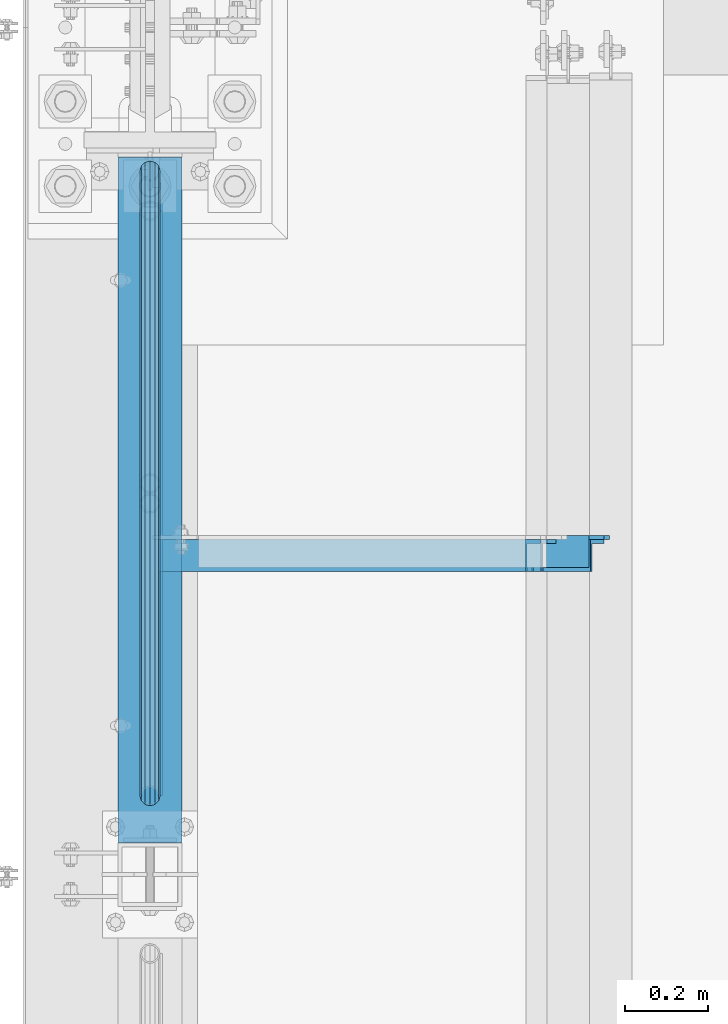
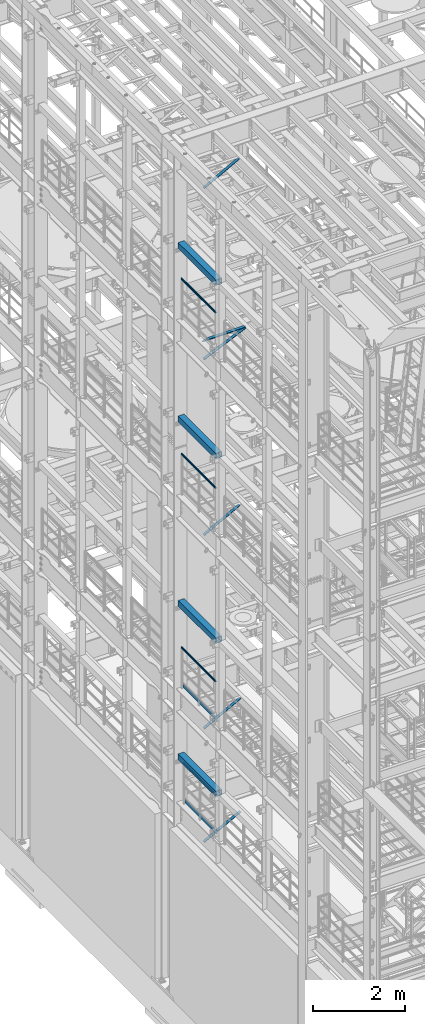
# One storey, part 1010 of 1876: 11 beams, 5 members, 14 elements without a shape of their own.
"""IFC2X3 building model written with IfcOpenShell, lengths in millimetres."""

from ifc_helpers import new_model, si_unit, frame, origin_with_axes, place, context, subcontext, project, spatial, faceted_brep, material, type_object, element, aggregate, save


model = new_model("IFC2X3")

# Units and contexts
model_context = context("Model", 3, precision=1e-05, world=origin_with_axes())
body_context = subcontext(model_context, "Body", "Model", "MODEL_VIEW")
ifc_project = project(units=[si_unit("LENGTHUNIT", "METRE", prefix="MILLI"), si_unit("AREAUNIT", "SQUARE_METRE"), si_unit("VOLUMEUNIT", "CUBIC_METRE"), si_unit("MASSUNIT", "GRAM", prefix="KILO"), si_unit("TIMEUNIT", "SECOND"), si_unit("PLANEANGLEUNIT", "RADIAN"), si_unit("SOLIDANGLEUNIT", "STERADIAN"), si_unit("THERMODYNAMICTEMPERATUREUNIT", "DEGREE_CELSIUS"), si_unit("LUMINOUSINTENSITYUNIT", "LUMEN")], contexts=[model_context])

# Site, building, storey
site_placement = place(None, origin_with_axes())
site = spatial("IfcSite", under=ifc_project, at=site_placement, CompositionType="ELEMENT")
building_placement = place(site_placement, origin_with_axes())
building = spatial("IfcBuilding", under=site, at=building_placement, Name="Undefined", CompositionType="ELEMENT")
storey_placement = place(building_placement, origin_with_axes())
storey = spatial("IfcBuildingStorey", under=building, at=storey_placement, Name="Undefined", CompositionType="ELEMENT", Elevation=0.0)

# Assembly, beam
assembly_1_placement = place(storey_placement, origin_with_axes())
assembly_1 = element("IfcElementAssembly", 1, at=assembly_1_placement, inside=storey, Name="RAIL", AssemblyPlace="NOTDEFINED", PredefinedType="RIGID_FRAME")
ifc_material_1 = material()
beam_type_1 = type_object("IfcBeamType", Name="PIPE1-1/2SCH40", PredefinedType="NOTDEFINED")
beam_1_placement = place(assembly_1_placement, frame((-1.81898940354586e-12, -342.900000000001, 19059.525), z_axis=(0.0, 0.0, -1.0), x_axis=(0.0, 1.0, 0.0)))
beam_1 = element("IfcBeam", 2, at=beam_1_placement, type_object=beam_type_1, material=ifc_material_1, Name="RAIL", ObjectType="PIPE1-1/2SCH40", context=body_context, shape_type="Brep", body=[
    faceted_brep([(24.1300000000001, -20.4469999999999, 0.0), (34.3535000000002, -17.7076214311803, 10.2235000000001), (1511.8715, -17.7076214311801, 10.2235000000001), (1522.095, -20.4470000000001, 0.0), (41.8376214311802, -10.2235000000001, 17.7076214311819), (1504.38737856882, -10.2235000000001, 17.7076214311819), (44.5770000000002, 0.0, 20.4470000000001), (1501.648, 0.0, 20.4470000000001), (41.8376214311802, 10.2235000000001, 17.7076214311819), (1504.38737856882, 10.2235000000001, 17.7076214311819), (34.3535000000002, 17.7076214311803, 10.2235000000001), (1511.8715, 17.7076214311801, 10.2235000000001), (24.1300000000001, 20.4469999999999, 0.0), (1522.095, 20.4470000000001, 0.0), (13.9065000000001, 17.7076214311803, -10.2235000000001), (1532.3185, 17.7076214311801, -10.2235000000001), (6.42237856882002, 10.2235000000001, -17.7076214311819), (1539.80262143118, 10.2235000000001, -17.7076214311819), (3.68299999999999, 0.0, -20.4470000000001), (1542.542, 0.0, -20.4470000000001), (6.42237856882002, -10.2235000000001, -17.7076214311819), (1539.80262143118, -10.2235000000001, -17.7076214311819), (13.9065000000001, -17.7076214311803, -10.2235000000001), (1532.3185, -17.7076214311801, -10.2235000000001), (24.1299999999854, -24.1299999999992, 0.0), (12.0650000000064, -20.8971929933177, -12.0649999999987), (1534.16, -20.8971929933186, -12.0649999999987), (1522.095, -24.1300000000001, 0.0), (3.23280700668147, -12.0650000000001, -20.8971929933177), (1542.99219299332, -12.0649999999996, -20.8971929933177), (-1.45519152283669e-11, 0.0, -24.130000000001), (1546.225, 0.0, -24.130000000001), (3.23280700668147, 12.0650000000001, -20.8971929933177), (1542.99219299332, 12.0649999999996, -20.8971929933177), (12.0650000000064, 20.8971929933177, -12.0649999999987), (1534.16, 20.8971929933186, -12.0649999999987), (24.1300000000047, 24.1299999999992, 0.0), (1522.095, 24.1300000000001, 0.0), (36.1949999999997, 20.8971929933184, 12.0649999999987), (1510.03, 20.8971929933186, 12.0649999999987), (45.0271929933187, 12.0650000000001, 20.8971929933177), (1501.19780700668, 12.0649999999996, 20.8971929933177), (48.2600000000002, 0.0, 24.130000000001), (1497.965, 0.0, 24.130000000001), (45.0271929933187, -12.0650000000001, 20.8971929933177), (1501.19780700668, -12.0649999999996, 20.8971929933177), (36.1949999999997, -20.8971929933184, 12.0649999999987), (1510.03, -20.8971929933186, 12.0649999999987)], [[[0, 1, 2, 3]], [[1, 4, 5, 2]], [[4, 6, 7, 5]], [[6, 8, 9, 7]], [[8, 10, 11, 9]], [[10, 12, 13, 11]], [[12, 14, 15, 13]], [[14, 16, 17, 15]], [[16, 18, 19, 17]], [[18, 20, 21, 19]], [[20, 22, 23, 21]], [[22, 0, 3, 23]], [[24, 25, 26, 27]], [[25, 28, 29, 26]], [[28, 30, 31, 29]], [[30, 32, 33, 31]], [[32, 34, 35, 33]], [[34, 36, 37, 35]], [[36, 38, 39, 37]], [[38, 40, 41, 39]], [[40, 42, 43, 41]], [[42, 44, 45, 43]], [[44, 46, 47, 45]], [[46, 24, 27, 47]], [[29, 31, 33, 35, 37, 39, 41, 43, 45, 47, 27, 26], [5, 7, 9, 11, 13, 15, 17, 19, 21, 23, 3, 2]], [[46, 44, 42, 40, 38, 36, 34, 32, 30, 28, 25, 24], [22, 20, 18, 16, 14, 12, 10, 8, 6, 4, 1, 0]]]),
])
aggregate(assembly_1, [beam_1])

assembly_2_placement = place(storey_placement, origin_with_axes())
assembly_2 = element("IfcElementAssembly", 3, at=assembly_2_placement, inside=storey, Name="RAIL", AssemblyPlace="NOTDEFINED", PredefinedType="RIGID_FRAME")
beam_2_placement = place(assembly_2_placement, frame((-1.81898940354586e-12, -342.900000000001, 14385.925), z_axis=(0.0, 0.0, -1.0), x_axis=(0.0, 1.0, 0.0)))
beam_2 = element("IfcBeam", 4, at=beam_2_placement, type_object=beam_type_1, material=ifc_material_1, Name="RAIL", ObjectType="PIPE1-1/2SCH40", context=body_context, shape_type="Brep", body=[
    faceted_brep([(24.1300000000001, -20.4469999999999, 0.0), (34.3535000000002, -17.7076214311803, 10.2235000000001), (1511.8715, -17.7076214311801, 10.2235000000001), (1522.095, -20.4470000000001, 0.0), (41.8376214311802, -10.2235000000001, 17.7076214311819), (1504.38737856882, -10.2235000000001, 17.7076214311819), (44.5770000000002, 0.0, 20.4470000000001), (1501.648, 0.0, 20.4470000000001), (41.8376214311802, 10.2235000000001, 17.7076214311819), (1504.38737856882, 10.2235000000001, 17.7076214311819), (34.3535000000002, 17.7076214311803, 10.2235000000001), (1511.8715, 17.7076214311801, 10.2235000000001), (24.1300000000001, 20.4469999999999, 0.0), (1522.095, 20.4470000000001, 0.0), (13.9065000000001, 17.7076214311803, -10.2235000000001), (1532.3185, 17.7076214311801, -10.2235000000001), (6.42237856882002, 10.2235000000001, -17.7076214311819), (1539.80262143118, 10.2235000000001, -17.7076214311819), (3.68299999999999, 0.0, -20.4470000000001), (1542.542, 0.0, -20.4470000000001), (6.42237856882002, -10.2235000000001, -17.7076214311819), (1539.80262143118, -10.2235000000001, -17.7076214311819), (13.9065000000001, -17.7076214311803, -10.2235000000001), (1532.3185, -17.7076214311801, -10.2235000000001), (24.1299999999854, -24.1299999999992, 0.0), (12.0650000000064, -20.8971929933177, -12.0649999999987), (1534.16, -20.8971929933186, -12.0649999999987), (1522.095, -24.1300000000001, 0.0), (3.23280700668147, -12.0650000000001, -20.8971929933177), (1542.99219299332, -12.0649999999996, -20.8971929933177), (-1.45519152283669e-11, 0.0, -24.130000000001), (1546.225, 0.0, -24.130000000001), (3.23280700668147, 12.0650000000001, -20.8971929933177), (1542.99219299332, 12.0649999999996, -20.8971929933177), (12.0650000000064, 20.8971929933177, -12.0649999999987), (1534.16, 20.8971929933186, -12.0649999999987), (24.1300000000047, 24.1299999999992, 0.0), (1522.095, 24.1300000000001, 0.0), (36.1949999999997, 20.8971929933184, 12.0649999999987), (1510.03, 20.8971929933186, 12.0649999999987), (45.0271929933187, 12.0650000000001, 20.8971929933177), (1501.19780700668, 12.0649999999996, 20.8971929933177), (48.2600000000002, 0.0, 24.130000000001), (1497.965, 0.0, 24.130000000001), (45.0271929933187, -12.0650000000001, 20.8971929933177), (1501.19780700668, -12.0649999999996, 20.8971929933177), (36.1949999999997, -20.8971929933184, 12.0649999999987), (1510.03, -20.8971929933186, 12.0649999999987)], [[[0, 1, 2, 3]], [[1, 4, 5, 2]], [[4, 6, 7, 5]], [[6, 8, 9, 7]], [[8, 10, 11, 9]], [[10, 12, 13, 11]], [[12, 14, 15, 13]], [[14, 16, 17, 15]], [[16, 18, 19, 17]], [[18, 20, 21, 19]], [[20, 22, 23, 21]], [[22, 0, 3, 23]], [[24, 25, 26, 27]], [[25, 28, 29, 26]], [[28, 30, 31, 29]], [[30, 32, 33, 31]], [[32, 34, 35, 33]], [[34, 36, 37, 35]], [[36, 38, 39, 37]], [[38, 40, 41, 39]], [[40, 42, 43, 41]], [[42, 44, 45, 43]], [[44, 46, 47, 45]], [[46, 24, 27, 47]], [[29, 31, 33, 35, 37, 39, 41, 43, 45, 47, 27, 26], [5, 7, 9, 11, 13, 15, 17, 19, 21, 23, 3, 2]], [[46, 44, 42, 40, 38, 36, 34, 32, 30, 28, 25, 24], [22, 20, 18, 16, 14, 12, 10, 8, 6, 4, 1, 0]]]),
])
aggregate(assembly_2, [beam_2])

assembly_3_placement = place(storey_placement, origin_with_axes())
assembly_3 = element("IfcElementAssembly", 5, at=assembly_3_placement, inside=storey, Name="RAIL", AssemblyPlace="NOTDEFINED", PredefinedType="RIGID_FRAME")
beam_3_placement = place(assembly_3_placement, frame((-1.81898940354586e-12, -342.900000000001, 9229.725), z_axis=(0.0, 0.0, -1.0), x_axis=(0.0, 1.0, 0.0)))
beam_3 = element("IfcBeam", 6, at=beam_3_placement, type_object=beam_type_1, material=ifc_material_1, Name="RAIL", ObjectType="PIPE1-1/2SCH40", context=body_context, shape_type="Brep", body=[
    faceted_brep([(24.1300000000001, -20.4469999999999, 0.0), (34.3535000000002, -17.7076214311803, 10.2235000000001), (1511.8715, -17.7076214311801, 10.2235000000001), (1522.095, -20.4470000000001, 0.0), (41.8376214311802, -10.2235000000001, 17.7076214311819), (1504.38737856882, -10.2235000000001, 17.7076214311819), (44.5770000000002, 0.0, 20.4470000000001), (1501.648, 0.0, 20.4470000000001), (41.8376214311802, 10.2235000000001, 17.7076214311819), (1504.38737856882, 10.2235000000001, 17.7076214311819), (34.3535000000002, 17.7076214311803, 10.2235000000001), (1511.8715, 17.7076214311801, 10.2235000000001), (24.1300000000001, 20.4469999999999, 0.0), (1522.095, 20.4470000000001, 0.0), (13.9065000000001, 17.7076214311803, -10.2235000000001), (1532.3185, 17.7076214311801, -10.2235000000001), (6.42237856882002, 10.2235000000001, -17.7076214311819), (1539.80262143118, 10.2235000000001, -17.7076214311819), (3.68299999999999, 0.0, -20.4470000000001), (1542.542, 0.0, -20.4470000000001), (6.42237856882002, -10.2235000000001, -17.7076214311819), (1539.80262143118, -10.2235000000001, -17.7076214311819), (13.9065000000001, -17.7076214311803, -10.2235000000001), (1532.3185, -17.7076214311801, -10.2235000000001), (24.1299999999854, -24.1299999999992, 0.0), (12.0650000000064, -20.8971929933177, -12.0649999999987), (1534.16, -20.8971929933186, -12.0649999999987), (1522.095, -24.1300000000001, 0.0), (3.23280700668147, -12.0650000000001, -20.8971929933177), (1542.99219299332, -12.0649999999996, -20.8971929933177), (-1.45519152283669e-11, 0.0, -24.130000000001), (1546.225, 0.0, -24.130000000001), (3.23280700668147, 12.0650000000001, -20.8971929933177), (1542.99219299332, 12.0649999999996, -20.8971929933177), (12.0650000000064, 20.8971929933177, -12.0649999999987), (1534.16, 20.8971929933186, -12.0649999999987), (24.1300000000047, 24.1299999999992, 0.0), (1522.095, 24.1300000000001, 0.0), (36.1949999999997, 20.8971929933184, 12.0649999999987), (1510.03, 20.8971929933186, 12.0649999999987), (45.0271929933187, 12.0650000000001, 20.8971929933177), (1501.19780700668, 12.0649999999996, 20.8971929933177), (48.2600000000002, 0.0, 24.130000000001), (1497.965, 0.0, 24.130000000001), (45.0271929933187, -12.0650000000001, 20.8971929933177), (1501.19780700668, -12.0649999999996, 20.8971929933177), (36.1949999999997, -20.8971929933184, 12.0649999999987), (1510.03, -20.8971929933186, 12.0649999999987)], [[[0, 1, 2, 3]], [[1, 4, 5, 2]], [[4, 6, 7, 5]], [[6, 8, 9, 7]], [[8, 10, 11, 9]], [[10, 12, 13, 11]], [[12, 14, 15, 13]], [[14, 16, 17, 15]], [[16, 18, 19, 17]], [[18, 20, 21, 19]], [[20, 22, 23, 21]], [[22, 0, 3, 23]], [[24, 25, 26, 27]], [[25, 28, 29, 26]], [[28, 30, 31, 29]], [[30, 32, 33, 31]], [[32, 34, 35, 33]], [[34, 36, 37, 35]], [[36, 38, 39, 37]], [[38, 40, 41, 39]], [[40, 42, 43, 41]], [[42, 44, 45, 43]], [[44, 46, 47, 45]], [[46, 24, 27, 47]], [[29, 31, 33, 35, 37, 39, 41, 43, 45, 47, 27, 26], [5, 7, 9, 11, 13, 15, 17, 19, 21, 23, 3, 2]], [[46, 44, 42, 40, 38, 36, 34, 32, 30, 28, 25, 24], [22, 20, 18, 16, 14, 12, 10, 8, 6, 4, 1, 0]]]),
])

assembly_4_placement = place(storey_placement, origin_with_axes())
assembly_4 = element("IfcElementAssembly", 7, at=assembly_4_placement, inside=storey, Name="RAIL", AssemblyPlace="NOTDEFINED", PredefinedType="RIGID_FRAME")
beam_4_placement = place(assembly_4_placement, frame((6.79847289575264e-10, 1108.0396633614, 6207.13724280096), z_axis=(0.0, 7.91400000045761e-06, -0.999999999968684), x_axis=(0.0, -0.999999999968684, -7.91400000071008e-06)))
beam_4 = element("IfcBeam", 8, at=beam_4_placement, type_object=beam_type_1, material=ifc_material_1, Name="RAIL", ObjectType="PIPE1-1/2SCH40", context=body_context, shape_type="Brep", body=[
    faceted_brep([(24.1297889306325, -20.4470000000001, 4.54747350886464e-12), (34.3533782626628, -17.7076214311801, 10.223500000001), (1416.58624781054, -17.7076214311801, 10.2235000002374), (1426.80965847928, -20.4470000000001, 2.42835085373372e-10), (41.8375650894295, -10.2235000000001, 17.7076214311801), (1409.10219177439, -10.2235000000001, 17.7076214314138), (44.5770000000002, 0.0, 20.4470000000001), (1406.3628371418, 0.0, 20.4470000002311), (41.8375650894295, 10.2235000000001, 17.7076214311801), (1409.10219177439, 10.2235000000001, 17.7076214314138), (34.3533782626628, 17.7076214311801, 10.223500000001), (1416.58624781054, 17.7076214311801, 10.2235000002374), (24.1297889306325, 20.4470000000001, 4.54747350886464e-12), (1426.80965847928, 20.4470000000001, 2.42835085373372e-10), (13.9061995986012, 17.7076214311801, -10.2234999999919), (1437.03306914802, 17.7076214311801, -10.2234999997499), (6.42201277183449, 10.2235000000001, -17.707621431171), (1444.51712518418, 10.2235000000001, -17.7076214309263), (3.68261026657001, 0.0, -20.4469999999901), (1447.25647981676, 0.0, -20.4469999997445), (6.42201277183449, -10.2235000000001, -17.707621431171), (1444.51712518418, -10.2235000000001, -17.7076214309263), (13.9061995986012, -17.7076214311801, -10.2234999999919), (1437.03306914802, -17.7076214311801, -10.2234999997499), (24.1297889306325, -24.1300000000001, 4.54747350886464e-12), (12.0646835077378, -20.8971929933186, -12.0649999999923), (1438.8745530573, -20.8971929933186, -12.0649999997486), (1426.80965847928, -24.1300000000001, 2.42835085373372e-10), (3.23241333950409, -12.0649999999996, -20.8971929933086), (1447.70666887637, -12.0649999999996, -20.8971929930613), (-0.000421915156039177, 0.0, -24.1299999999892), (1450.93944763532, 0.0, -24.1299999997409), (3.23241333950409, 12.0649999999996, -20.8971929933086), (1447.70666887637, 12.0649999999996, -20.8971929930613), (12.0646835077378, 20.8971929933186, -12.0649999999923), (1438.8745530573, 20.8971929933186, -12.0649999997486), (24.1297889306325, 24.1300000000001, 4.54747350886464e-12), (1426.80965847928, 24.1300000000001, 2.42835085373372e-10), (36.1948943535272, 20.8971929933186, 12.0650000000014), (1414.74476390127, 20.8971929933186, 12.0650000002352), (45.0271929933187, 12.0650000000001, 20.8971929933177), (1405.9126480822, 12.0649999999996, 20.8971929935497), (48.2600000000002, 0.0, 24.130000000001), (1402.67986932325, 0.0, 24.1300000002293), (45.0271929933187, -12.0650000000001, 20.8971929933177), (1405.9126480822, -12.0649999999996, 20.8971929935497), (36.1948943535263, -20.8971929933186, 12.0650000000014), (1414.74476390127, -20.8971929933186, 12.0650000002352)], [[[0, 1, 2, 3]], [[1, 4, 5, 2]], [[4, 6, 7, 5]], [[6, 8, 9, 7]], [[8, 10, 11, 9]], [[10, 12, 13, 11]], [[12, 14, 15, 13]], [[14, 16, 17, 15]], [[16, 18, 19, 17]], [[18, 20, 21, 19]], [[20, 22, 23, 21]], [[22, 0, 3, 23]], [[24, 25, 26, 27]], [[25, 28, 29, 26]], [[28, 30, 31, 29]], [[30, 32, 33, 31]], [[32, 34, 35, 33]], [[34, 36, 37, 35]], [[36, 38, 39, 37]], [[38, 40, 41, 39]], [[40, 42, 43, 41]], [[42, 44, 45, 43]], [[44, 46, 47, 45]], [[46, 24, 27, 47]], [[29, 31, 33, 35, 37, 39, 41, 43, 45, 47, 27, 26], [5, 7, 9, 11, 13, 15, 17, 19, 21, 23, 3, 2]], [[46, 44, 42, 40, 38, 36, 34, 32, 30, 28, 25, 24], [22, 20, 18, 16, 14, 12, 10, 8, 6, 4, 1, 0]]]),
])

assembly_5_placement = place(storey_placement, origin_with_axes())
assembly_5 = element("IfcElementAssembly", 9, at=assembly_5_placement, inside=storey, Name="BEAM", AssemblyPlace="NOTDEFINED", PredefinedType="RIGID_FRAME")
ifc_material_2 = material()
beam_type_2 = type_object("IfcBeamType", Name="HSS6X6X3/8", PredefinedType="NOTDEFINED")
beam_5_placement = place(assembly_5_placement, frame((0.0, -508.0, 19958.05), z_axis=(-1.0, 0.0, 0.0), x_axis=(0.0, 1.0, 0.0)))
beam_5 = element("IfcBeam", 10, at=beam_5_placement, type_object=beam_type_2, material=ifc_material_2, Name="BEAM", ObjectType="HSS6X6X3/8", context=body_context, shape_type="Brep", body=[
    faceted_brep([(76.2000000000007, 66.6749999999993, -66.6750000000002), (76.2000000000007, -66.6749999999993, -66.6750000000002), (1720.85, -66.6749999999993, -66.675), (1720.85, 66.6749999999993, -66.675), (76.2000000000007, -66.6749999999993, 66.6750000000002), (1720.85, -66.6749999999993, 66.675), (76.2000000000007, 66.6749999999993, 66.6750000000002), (1720.85, 66.6749999999993, 66.675), (76.2000000000007, 76.2000000000007, -76.1999999999998), (76.2000000000007, 76.2000000000007, 76.1999999999998), (1720.85, 76.2000000000007, 76.2), (1720.85, 76.2000000000007, -76.2), (76.2000000000007, -76.2000000000007, 76.1999999999998), (1720.85, -76.2000000000007, 76.2), (76.2000000000007, -76.2000000000007, -76.1999999999998), (1720.85, -76.2000000000007, -76.2)], [[[0, 1, 2, 3]], [[1, 4, 5, 2]], [[4, 6, 7, 5]], [[6, 0, 3, 7]], [[8, 9, 10, 11]], [[9, 12, 13, 10]], [[12, 14, 15, 13]], [[14, 8, 11, 15]], [[13, 15, 11, 10], [5, 7, 3, 2]], [[14, 12, 9, 8], [6, 4, 1, 0]]]),
])
aggregate(assembly_5, [beam_5])

assembly_6_placement = place(storey_placement, origin_with_axes())
assembly_6 = element("IfcElementAssembly", 11, at=assembly_6_placement, inside=storey, Name="BEAM", AssemblyPlace="NOTDEFINED", PredefinedType="RIGID_FRAME")
beam_6_placement = place(assembly_6_placement, frame((0.0, -508.0, 15335.25), z_axis=(-1.0, 0.0, 0.0), x_axis=(0.0, 1.0, 0.0)))
beam_6 = element("IfcBeam", 12, at=beam_6_placement, type_object=beam_type_2, material=ifc_material_2, Name="BEAM", ObjectType="HSS6X6X3/8", context=body_context, shape_type="Brep", body=[
    faceted_brep([(76.2000000000007, 66.6749999999993, -66.6750000000002), (76.2000000000007, -66.6749999999993, -66.6750000000002), (1720.85, -66.6749999999993, -66.675), (1720.85, 66.6749999999993, -66.675), (76.2000000000007, -66.6749999999993, 66.6750000000002), (1720.85, -66.6749999999993, 66.675), (76.2000000000007, 66.6749999999993, 66.6750000000002), (1720.85, 66.6749999999993, 66.675), (76.2000000000007, 76.2000000000007, -76.1999999999998), (76.2000000000007, 76.2000000000007, 76.1999999999998), (1720.85, 76.2000000000007, 76.2), (1720.85, 76.2000000000007, -76.2), (76.2000000000007, -76.2000000000007, 76.1999999999998), (1720.85, -76.2000000000007, 76.2), (76.2000000000007, -76.2000000000007, -76.1999999999998), (1720.85, -76.2000000000007, -76.2)], [[[0, 1, 2, 3]], [[1, 4, 5, 2]], [[4, 6, 7, 5]], [[6, 0, 3, 7]], [[8, 9, 10, 11]], [[9, 12, 13, 10]], [[12, 14, 15, 13]], [[14, 8, 11, 15]], [[13, 15, 11, 10], [5, 7, 3, 2]], [[14, 12, 9, 8], [6, 4, 1, 0]]]),
])
aggregate(assembly_6, [beam_6])

assembly_7_placement = place(storey_placement, origin_with_axes())
assembly_7 = element("IfcElementAssembly", 13, at=assembly_7_placement, inside=storey, Name="BEAM", AssemblyPlace="NOTDEFINED", PredefinedType="RIGID_FRAME")
beam_7_placement = place(assembly_7_placement, frame((0.0, -508.0, 10420.35), z_axis=(-1.0, 0.0, 0.0), x_axis=(0.0, 1.0, 0.0)))
beam_7 = element("IfcBeam", 14, at=beam_7_placement, type_object=beam_type_2, material=ifc_material_2, Name="BEAM", ObjectType="HSS6X6X3/8", context=body_context, shape_type="Brep", body=[
    faceted_brep([(76.2000000000007, 66.6749999999993, -66.6750000000002), (76.2000000000007, -66.6749999999993, -66.6750000000002), (1720.85, -66.6749999999993, -66.675), (1720.85, 66.6749999999993, -66.675), (76.2000000000007, -66.6749999999993, 66.6750000000002), (1720.85, -66.6749999999993, 66.675), (76.2000000000007, 66.6749999999993, 66.6750000000002), (1720.85, 66.6749999999993, 66.675), (76.2000000000007, 76.2000000000007, -76.1999999999998), (76.2000000000007, 76.2000000000007, 76.1999999999998), (1720.85, 76.2000000000007, 76.2), (1720.85, 76.2000000000007, -76.2), (76.2000000000007, -76.2000000000007, 76.1999999999998), (1720.85, -76.2000000000007, 76.2), (76.2000000000007, -76.2000000000007, -76.1999999999998), (1720.85, -76.2000000000007, -76.2)], [[[0, 1, 2, 3]], [[1, 4, 5, 2]], [[4, 6, 7, 5]], [[6, 0, 3, 7]], [[8, 9, 10, 11]], [[9, 12, 13, 10]], [[12, 14, 15, 13]], [[14, 8, 11, 15]], [[13, 15, 11, 10], [5, 7, 3, 2]], [[14, 12, 9, 8], [6, 4, 1, 0]]]),
])
aggregate(assembly_7, [beam_7])

assembly_8_placement = place(storey_placement, origin_with_axes())
assembly_8 = element("IfcElementAssembly", 15, at=assembly_8_placement, inside=storey, Name="BEAM", AssemblyPlace="NOTDEFINED", PredefinedType="RIGID_FRAME")
beam_8_placement = place(assembly_8_placement, frame((0.0, -508.0, 6330.95), z_axis=(-1.0, 0.0, 0.0), x_axis=(0.0, 1.0, 0.0)))
beam_8 = element("IfcBeam", 16, at=beam_8_placement, type_object=beam_type_2, material=ifc_material_2, Name="BEAM", ObjectType="HSS6X6X3/8", context=body_context, shape_type="Brep", body=[
    faceted_brep([(76.2000000000007, 66.6749999999993, -66.6750000000002), (76.2000000000007, -66.6749999999993, -66.6750000000002), (1720.85, -66.6749999999993, -66.675), (1720.85, 66.6749999999993, -66.675), (76.2000000000007, -66.6749999999993, 66.6750000000002), (1720.85, -66.6749999999993, 66.675), (76.2000000000007, 66.6749999999993, 66.6750000000002), (1720.85, 66.6749999999993, 66.675), (76.2000000000007, 76.2000000000007, -76.1999999999998), (76.2000000000007, 76.2000000000007, 76.1999999999998), (1720.85, 76.2000000000007, 76.2), (1720.85, 76.2000000000007, -76.2), (76.2000000000007, -76.2000000000007, 76.1999999999998), (1720.85, -76.2000000000007, 76.2), (76.2000000000007, -76.2000000000007, -76.1999999999998), (1720.85, -76.2000000000007, -76.2)], [[[0, 1, 2, 3]], [[1, 4, 5, 2]], [[4, 6, 7, 5]], [[6, 0, 3, 7]], [[8, 9, 10, 11]], [[9, 12, 13, 10]], [[12, 14, 15, 13]], [[14, 8, 11, 15]], [[13, 15, 11, 10], [5, 7, 3, 2]], [[14, 12, 9, 8], [6, 4, 1, 0]]]),
])
aggregate(assembly_8, [beam_8])

# Beam
ifc_material_3 = material(Name="STEEL/A36")
beam_type_3 = type_object("IfcBeamType", PredefinedType="NOTDEFINED")
beam_9_placement = place(assembly_3_placement, frame((27.3049999999948, -318.769999999999, 8220.08091229478), z_axis=(0.0, 0.0, 1.0), x_axis=(0.0, 1.0, 0.0)))
beam_9 = element("IfcBeam", 17, at=beam_9_placement, type_object=beam_type_3, material=ifc_material_3, Name="PLATE", context=body_context, shape_type="Brep", body=[
    faceted_brep([(0.0, 3.17500000000018, -50.8000000000002), (0.0, 3.17500000000018, 50.8000000000002), (1497.965, 3.175, 50.7999999999993), (1497.965, 3.175, -50.7999999999993), (0.0, -3.17500000000018, 50.8000000000002), (1497.965, -3.175, 50.7999999999993), (0.0, -3.17500000000018, -50.8000000000002), (1497.965, -3.175, -50.7999999999993)], [[[0, 1, 2, 3]], [[1, 4, 5, 2]], [[4, 6, 7, 5]], [[6, 0, 3, 7]], [[5, 7, 3, 2]], [[6, 4, 1, 0]]]),
])

aggregate(assembly_3, [beam_9, beam_3])

beam_10_placement = place(assembly_4_placement, frame((27.3049999999948, -318.770000000004, 5197.48091229478), z_axis=(0.0, 0.0, 1.0), x_axis=(0.0, 1.0, 0.0)))
beam_10 = element("IfcBeam", 18, at=beam_10_placement, type_object=beam_type_3, material=ifc_material_3, Name="PLATE", context=body_context, shape_type="Brep", body=[
    faceted_brep([(0.0, 3.17500000000018, -50.8000000000002), (0.0, 3.17500000000018, 50.8000000000002), (1402.6796633614, 3.175, 50.8000000000002), (1402.6796633614, 3.175, -50.8000000000002), (0.0, -3.17500000000018, 50.8000000000002), (1402.6796633614, -3.175, 50.8000000000002), (0.0, -3.17500000000018, -50.8000000000002), (1402.6796633614, -3.175, -50.8000000000002)], [[[0, 1, 2, 3]], [[1, 4, 5, 2]], [[4, 6, 7, 5]], [[6, 0, 3, 7]], [[5, 7, 3, 2]], [[6, 4, 1, 0]]]),
])

aggregate(assembly_4, [beam_10, beam_4])

# Assembly, member
assembly_9_placement = place(storey_placement, origin_with_axes())
assembly_9 = element("IfcElementAssembly", 19, at=assembly_9_placement, inside=storey, AssemblyPlace="NOTDEFINED", PredefinedType="RIGID_FRAME")
member_type = type_object("IfcMemberType", Name="L3X3X3/8", PredefinedType="NOTDEFINED")
member_1_placement = place(assembly_9_placement, frame((17.8851909627118, 257.174999999999, 4576.45883178417), z_axis=(0.0, -1.0, 0.0), x_axis=(0.882970975303512, 0.0, 0.469427584161354)))
member_1 = element("IfcMember", 20, at=member_1_placement, type_object=member_type, material=ifc_material_3, ObjectType="L3X3X3/8", context=body_context, shape_type="Brep", body=[
    faceted_brep([(22.4738417769599, 38.1000000000004, -38.0999999999999), (22.4738417769599, 38.1000000000004, 38.0999999999999), (1061.87831940918, 38.0999999998248, 38.0999999999999), (1061.87831940918, 38.0999999998248, -38.0999999999999), (22.4738417769613, 28.5749999999998, 38.0999999999999), (1061.87831940918, 28.5749999998243, 38.0999999999999), (22.4738417769613, 28.5749999999998, -28.5749999999998), (1061.87831940918, 28.5749999998243, -28.5749999999998), (22.4738417769699, -38.100000000004, -28.5749999999998), (1061.87831940919, -38.1000000001804, -28.5749999999998), (22.4738417769699, -38.100000000004, -38.0999999999999), (1061.87831940919, -38.1000000001804, -38.0999999999999)], [[[0, 1, 2, 3]], [[1, 4, 5, 2]], [[4, 6, 7, 5]], [[6, 8, 9, 7]], [[8, 10, 11, 9]], [[10, 0, 3, 11]], [[5, 7, 9, 11, 3, 2]], [[10, 8, 6, 4, 1, 0]]]),
])
aggregate(assembly_9, [member_1])

assembly_10_placement = place(storey_placement, origin_with_axes())
assembly_10 = element("IfcElementAssembly", 21, at=assembly_10_placement, inside=storey, AssemblyPlace="NOTDEFINED", PredefinedType="RIGID_FRAME")
member_2_placement = place(assembly_10_placement, frame((18.2754879686868, 257.174999999997, 22001.0692535961), z_axis=(0.0, -1.0, 0.0), x_axis=(0.877448093107104, 0.0, 0.479671600058526)))
member_2 = element("IfcMember", 22, at=member_2_placement, type_object=member_type, material=ifc_material_3, ObjectType="L3X3X3/8", context=body_context, shape_type="Brep", body=[
    faceted_brep([(22.6152978728696, 38.0999999999985, -38.0999999999999), (22.6152978728696, 38.0999999999985, 38.0999999999999), (1025.78606203808, 38.1000000013628, 38.0999999999999), (1025.78606203808, 38.1000000013628, -38.0999999999999), (22.6152978728605, 28.5750000000044, 38.0999999999999), (1025.78606203807, 28.5750000013722, 38.0999999999999), (22.6152978728605, 28.5750000000044, -28.5749999999998), (1025.78606203807, 28.5750000013722, -28.5749999999998), (22.6152978728023, -38.0999999999367, -28.5749999999998), (1025.78606203801, -38.0999999985652, -28.5749999999998), (22.6152978728023, -38.0999999999367, -38.0999999999999), (1025.78606203801, -38.0999999985652, -38.0999999999999)], [[[0, 1, 2, 3]], [[1, 4, 5, 2]], [[4, 6, 7, 5]], [[6, 8, 9, 7]], [[8, 10, 11, 9]], [[10, 0, 3, 11]], [[5, 7, 9, 11, 3, 2]], [[10, 8, 6, 4, 1, 0]]]),
])
aggregate(assembly_10, [member_2])

assembly_11_placement = place(storey_placement, origin_with_axes())
assembly_11 = element("IfcElementAssembly", 23, at=assembly_11_placement, inside=storey, AssemblyPlace="NOTDEFINED", PredefinedType="RIGID_FRAME")
member_3_placement = place(assembly_11_placement, frame((15.9156353109858, 257.175, 17440.5834930797), z_axis=(0.0, -1.0, 0.0), x_axis=(0.908569735485921, 0.0, 0.417733211223436)))
member_3 = element("IfcMember", 24, at=member_3_placement, type_object=member_type, material=ifc_material_3, ObjectType="L3X3X3/8", context=body_context, shape_type="Brep", body=[
    faceted_brep([(21.8406460853457, 38.0999999999894, -38.0999999999999), (21.8406460853457, 38.0999999999894, 38.0999999999999), (1162.88335939537, 38.0999999996566, 38.0999999999999), (1162.88335939537, 38.0999999996566, -38.0999999999999), (21.8406460853494, 28.5749999999916, 38.0999999999999), (1162.88335939538, 28.5749999996551, 38.0999999999999), (21.8406460853494, 28.5749999999916, -28.5749999999998), (1162.88335939538, 28.5749999996551, -28.5749999999998), (21.8406460853721, -38.1000000000022, -28.5749999999998), (1162.8833593954, -38.1000000003332, -28.5749999999998), (21.8406460853721, -38.1000000000022, -38.0999999999999), (1162.8833593954, -38.1000000003332, -38.0999999999999)], [[[0, 1, 2, 3]], [[1, 4, 5, 2]], [[4, 6, 7, 5]], [[6, 8, 9, 7]], [[8, 10, 11, 9]], [[10, 0, 3, 11]], [[5, 7, 9, 11, 3, 2]], [[10, 8, 6, 4, 1, 0]]]),
])
aggregate(assembly_11, [member_3])

assembly_12_placement = place(storey_placement, origin_with_axes())
assembly_12 = element("IfcElementAssembly", 25, at=assembly_12_placement, inside=storey, AssemblyPlace="NOTDEFINED", PredefinedType="RIGID_FRAME")
member_4_placement = place(assembly_12_placement, frame((17.8851909639217, 257.174999999999, 7599.05883178481), z_axis=(0.0, -1.0, 0.0), x_axis=(0.882970975303512, 0.0, 0.469427584161354)))
member_4 = element("IfcMember", 26, at=member_4_placement, type_object=member_type, material=ifc_material_3, ObjectType="L3X3X3/8", context=body_context, shape_type="Brep", body=[
    faceted_brep([(22.4738417769599, 38.1000000000004, -38.0999999999999), (22.4738417769599, 38.1000000000004, 38.0999999999999), (1061.87831940918, 38.0999999998248, 38.0999999999999), (1061.87831940918, 38.0999999998248, -38.0999999999999), (22.4738417769613, 28.5749999999998, 38.0999999999999), (1061.87831940918, 28.5749999998243, 38.0999999999999), (22.4738417769613, 28.5749999999998, -28.5749999999998), (1061.87831940918, 28.5749999998243, -28.5749999999998), (22.4738417769699, -38.100000000004, -28.5749999999998), (1061.87831940919, -38.1000000001804, -28.5749999999998), (22.4738417769699, -38.100000000004, -38.0999999999999), (1061.87831940919, -38.1000000001804, -38.0999999999999)], [[[0, 1, 2, 3]], [[1, 4, 5, 2]], [[4, 6, 7, 5]], [[6, 8, 9, 7]], [[8, 10, 11, 9]], [[10, 0, 3, 11]], [[5, 7, 9, 11, 3, 2]], [[10, 8, 6, 4, 1, 0]]]),
])
aggregate(assembly_12, [member_4])

assembly_13_placement = place(storey_placement, origin_with_axes())
assembly_13 = element("IfcElementAssembly", 27, at=assembly_13_placement, inside=storey, Name="BRACE", AssemblyPlace="NOTDEFINED", PredefinedType="RIGID_FRAME")
member_5_placement = place(assembly_13_placement, frame((18.2145803608532, 257.175000000001, 12755.4360034921), z_axis=(0.0, -1.0, 0.0), x_axis=(0.878320118391342, 0.0, 0.478072975213009)))
member_5 = element("IfcMember", 28, at=member_5_placement, type_object=member_type, material=ifc_material_3, Name="BRACE", ObjectType="L3X3X3/8", context=body_context, shape_type="Brep", body=[
    faceted_brep([(1042.67554503748, -38.1000000001168, -28.5749999999998), (1042.67554503748, -38.1000000001168, -38.0999999999999), (1042.67554503746, 38.0999999998312, -38.0999999999999), (1042.67554503746, 38.0999999998312, 38.0999999999999), (1042.67554503746, 28.5749999998388, 38.0999999999999), (1042.67554503746, 28.5749999998388, -28.5749999999998), (22.5928446582657, 28.5749999999789, 38.0999999999999), (22.5928446582657, 28.5749999999789, -28.5749999999998), (22.5928446582811, -38.0999999999749, -28.5749999999998), (22.5928446582811, -38.0999999999749, -38.0999999999999), (22.592844658262, 38.0999999999713, -38.0999999999999), (22.592844658262, 38.0999999999713, 38.0999999999999)], [[[0, 1, 2, 3, 4, 5]], [[5, 4, 6, 7]], [[0, 5, 7, 8]], [[1, 0, 8, 9]], [[2, 1, 9, 10]], [[3, 2, 10, 11]], [[4, 3, 11, 6]], [[10, 9, 8, 7, 6, 11]]]),
])
aggregate(assembly_13, [member_5])

# Assembly, beam
assembly_14_placement = place(storey_placement, origin_with_axes())
assembly_14 = element("IfcElementAssembly", 29, at=assembly_14_placement, inside=storey, Name="ANGLE", AssemblyPlace="NOTDEFINED", PredefinedType="RIGID_FRAME")
beam_type_4 = type_object("IfcBeamType", Name="L3X3X3/8", PredefinedType="NOTDEFINED")
beam_11_placement = place(assembly_14_placement, frame((-4.9349605127382e-08, 266.7, 17945.1), z_axis=(0.0, -1.0, 0.0), x_axis=(1.0, 0.0, 0.0)))
beam_11 = element("IfcBeam", 30, at=beam_11_placement, type_object=beam_type_4, material=ifc_material_3, Name="ANGLE", ObjectType="L3X3X3/8", context=body_context, shape_type="Brep", body=[
    faceted_brep([(115.886999817316, 28.5750000000007, 38.0999999999999), (115.886999817316, 38.0999999999985, 38.0999999999999), (115.886998826692, 38.0999999999985, -38.0999999999999), (115.88699882669, 12.699999237062, -38.0999999999999), (115.886998950515, 12.699999237062, -28.5749999999998), (115.88699895052, 28.5750000000007, -28.5749999999998), (38.8937432114558, 12.699999237062, -38.0999999999999), (38.8937433352807, 12.699999237062, -28.5749999999998), (7.14374321145577, -19.050000762938, -38.0999999999999), (7.14374333528067, -19.050000762938, -28.5749999999998), (7.1437499954859, -38.0999999999985, -38.0999999999999), (7.1437499954859, -38.0999999999985, -28.5749999999998), (1101.72500281572, 15.8750003814712, -28.5749999999998), (1089.02500300646, 28.5750000000007, -28.5749999999998), (1052.51300101518, 28.5750000000007, -28.5749999999998), (1101.72500039161, -38.0999999999985, -28.5749999999998), (1101.72500281572, 3.17500152588036, -28.5749999999998), (1052.51300281541, 28.5750000000007, 38.0999999999999), (1052.5130028154, 38.0999999999985, 38.0999999999999), (1052.513000758, 38.0999999999985, -38.0999999999999), (1052.51300075801, 28.5750001907363, -38.0999999999999), (1089.02500274928, 28.5750001907363, -38.0999999999999), (1101.72500255855, 15.8750003814712, -38.0999999999999), (1101.72500255855, 3.17500152588036, -38.0999999999999), (1101.72500039161, -38.0999999999985, -38.0999999999999)], [[[0, 1, 2, 3, 4, 5]], [[4, 3, 6, 7]], [[7, 6, 8, 9]], [[8, 10, 11, 9]], [[12, 13, 14, 5, 4, 7, 9, 11, 15, 16]], [[0, 5, 14, 17]], [[1, 0, 17, 18]], [[2, 1, 18, 19]], [[17, 14, 20, 19, 18]], [[13, 21, 20, 14]], [[12, 22, 21, 13]], [[16, 23, 22, 12]], [[10, 8, 6, 3, 2, 19, 20, 21, 22, 23, 24]], [[11, 10, 24, 15]], [[23, 16, 15, 24]]]),
])
aggregate(assembly_14, [beam_11])

save(model, "model.ifc")
